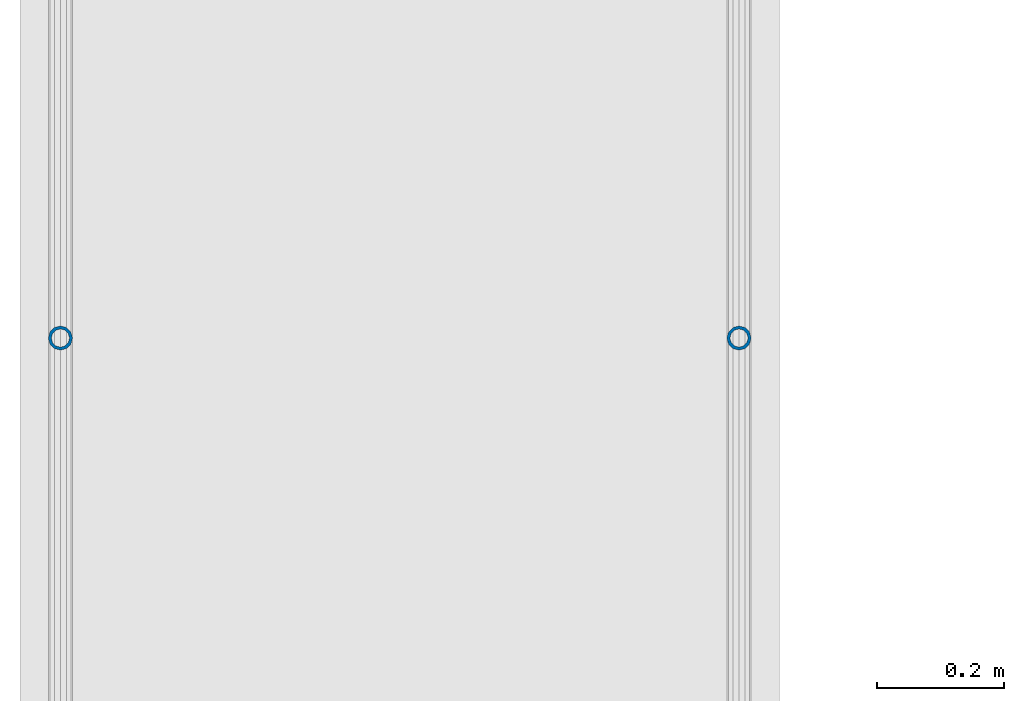
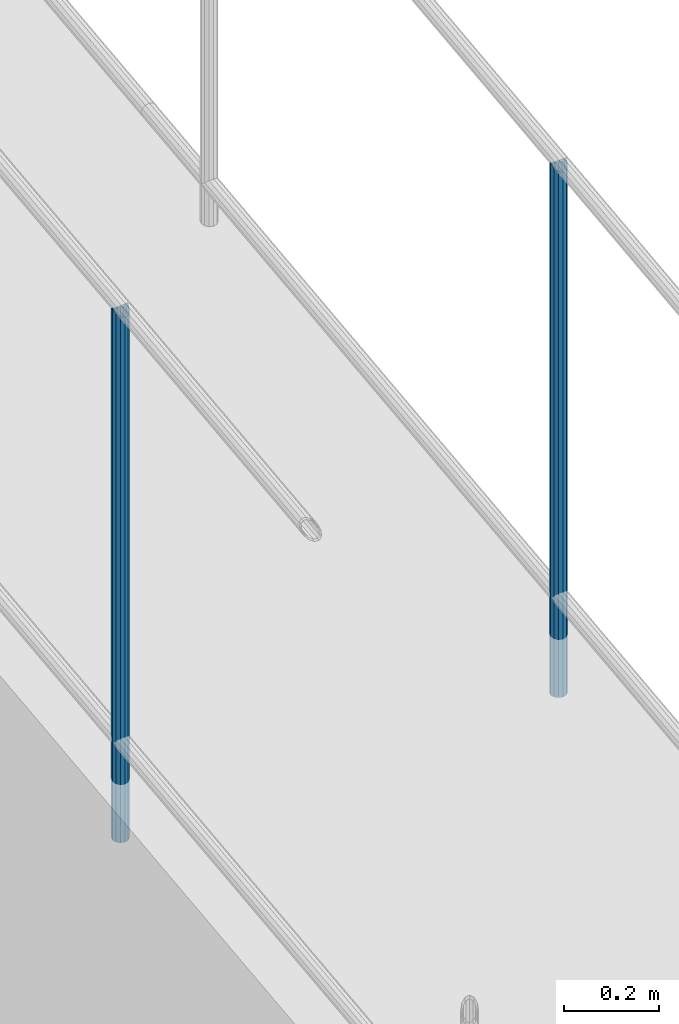
# One storey, part 875 of 1763: 2 columns, 2 elements without a shape of their own.
"""IFC2X3 building model written with IfcOpenShell, lengths in millimetres."""

from ifc_helpers import new_model, si_unit, frame, origin_with_axes, place, context, subcontext, project, spatial, faceted_brep, material, type_object, element, aggregate, save


model = new_model("IFC2X3")

# Units and contexts
model_context = context("Model", 3, precision=1e-05, world=origin_with_axes())
body_context = subcontext(model_context, "Body", "Model", "MODEL_VIEW")
ifc_project = project(units=[si_unit("LENGTHUNIT", "METRE", prefix="MILLI"), si_unit("AREAUNIT", "SQUARE_METRE"), si_unit("VOLUMEUNIT", "CUBIC_METRE"), si_unit("MASSUNIT", "GRAM", prefix="KILO"), si_unit("TIMEUNIT", "SECOND"), si_unit("PLANEANGLEUNIT", "RADIAN"), si_unit("SOLIDANGLEUNIT", "STERADIAN"), si_unit("THERMODYNAMICTEMPERATUREUNIT", "DEGREE_CELSIUS"), si_unit("LUMINOUSINTENSITYUNIT", "LUMEN")], contexts=[model_context])

# Site, building, storey
site_placement = place(None, origin_with_axes())
site = spatial("IfcSite", under=ifc_project, at=site_placement, CompositionType="ELEMENT")
building_placement = place(site_placement, origin_with_axes())
building = spatial("IfcBuilding", under=site, at=building_placement, Name="Undefined", CompositionType="ELEMENT")
storey_placement = place(building_placement, origin_with_axes())
storey = spatial("IfcBuildingStorey", under=building, at=storey_placement, Name="Undefined", CompositionType="ELEMENT", Elevation=0.0)

# Assembly, column
assembly_1_placement = place(storey_placement, origin_with_axes())
assembly_1 = element("IfcElementAssembly", 1, at=assembly_1_placement, inside=storey, Name="GUARDRAIL", AssemblyPlace="NOTDEFINED", PredefinedType="RIGID_FRAME")
ifc_material = material(Name="STEEL/A513")
column_type = type_object("IfcColumnType", PredefinedType="NOTDEFINED")
column_1_placement = place(assembly_1_placement, frame((-97200.6527017878, -3943.5626767489, 4576.43044701569), z_axis=(0.0, -0.999999999989044, 4.68099999989136e-06), x_axis=(0.0, 4.68100000009712e-06, 0.999999999989044)))
column_1 = element("IfcColumn", 2, at=column_1_placement, type_object=column_type, material=ifc_material, Name="POST TUBE", context=body_context, shape_type="Brep", body=[
    faceted_brep([(1371.60074802696, 19.0500000000029, -4.95674612466246e-10), (1360.91954353543, 16.4977839420899, 9.52499999992688), (1363.1068023618, 16.4977839420899, -9.52500000007285), (1352.93166657158, -7.14375000000291, 12.3733379564974), (1350.78515091293, 0.0, 14.2874999999276), (1350.23833620634, 0.0, 19.0499999999279), (1353.10035708436, -9.52499999999418, 16.4977839420208), (1353.84731986472, -9.52499999997963, 9.99208795651202), (1353.84731986473, 9.52500000000873, 9.99208795648292), (1353.10035708436, 9.52499999999418, 16.4977839420208), (1352.93166657157, 7.14375000000291, 12.3733379564974), (1357.04140787087, 12.3733379565674, 7.14374999992697), (1359.7883677507, 14.2875000000058, -7.27595761418343e-11), (1358.68185199063, 12.3733379565674, -7.14375000007294), (1356.14183772056, 9.52500000000873, -9.99208795662844), (1356.88880050093, 9.52499999999418, -16.4977839421663), (1355.77299913398, 7.14375000000291, -12.3733379566434), (1354.06603915248, 0.0, -14.2875000000727), (1354.61285385908, 0.0, -19.0500000000725), (1355.77299913399, -7.14375000000291, -12.3733379566434), (1356.14183772056, -9.52499999997963, -9.992087956658), (1356.88880050093, -9.52499999999418, -16.4977839421663), (1371.60075086449, -19.0499999999884, 1.21417542686686e-10), (1363.1068023618, -16.4977839420899, -9.52500000007285), (1360.91954353543, -16.4977839420899, 9.52499999992688), (1358.68185199066, -12.3733379565674, -7.14375000007294), (1359.78836775073, -14.2875000000058, -7.27595761418343e-11), (1357.0414078709, -12.3733379565674, 7.14374999992697), (0.0, -16.4977839420899, -9.52500000000146), (0.0, -9.52499999999418, -16.4977839420935), (1.45519152283669e-11, 1.81898940354586e-12, -19.0499999999993), (0.0, 9.52499999999418, -16.4977839420935), (0.0, 16.4977839420899, -9.52500000000146), (0.0, 19.0500000000029, 0.0), (0.0, 16.4977839420899, 9.52500000000146), (0.0, 9.52499999999418, 16.4977839420935), (1.45519152283669e-11, 1.81898940354586e-12, 19.0499999999993), (0.0, -9.52499999999418, 16.4977839420935), (0.0, -16.4977839420899, 9.52500000000146), (0.0, -19.0500000000029, 0.0), (0.0, -12.3733379565674, -7.14374999999927), (0.0, -7.14375000000291, -12.373337956571), (0.0, 0.0, -14.2874999999985), (0.0, 7.14375000000291, -12.373337956571), (0.0, 12.3733379565674, -7.14374999999927), (0.0, 14.2875000000058, 0.0), (0.0, 12.3733379565674, 7.14374999999927), (0.0, 7.14375000000291, 12.373337956571), (0.0, 0.0, 14.2874999999985), (0.0, -7.14375000000291, 12.373337956571), (0.0, -12.3733379565674, 7.14374999999927), (0.0, -14.2875000000058, 0.0)], [[[0, 1, 2]], [[3, 4, 5, 6, 7]], [[8, 9, 5, 4, 10]], [[2, 1, 9, 8, 11, 12, 13, 14, 15]], [[15, 14, 16, 17, 18]], [[18, 17, 19, 20, 21]], [[22, 23, 24]], [[21, 20, 25, 26, 27, 7, 6, 24, 23]], [[28, 29, 21, 23]], [[29, 30, 18, 21]], [[30, 31, 15, 18]], [[31, 32, 2, 15]], [[32, 33, 0, 2]], [[33, 34, 1, 0]], [[34, 35, 9, 1]], [[35, 36, 5, 9]], [[36, 37, 6, 5]], [[37, 38, 24, 6]], [[38, 39, 22, 24]], [[39, 28, 23, 22]], [[38, 37, 36, 35, 34, 33, 32, 31, 30, 29, 28, 39], [40, 41, 42, 43, 44, 45, 46, 47, 48, 49, 50, 51]], [[40, 51, 26, 25]], [[19, 41, 40, 25, 20]], [[42, 41, 19, 17]], [[43, 42, 17, 16]], [[44, 43, 16, 14, 13]], [[45, 44, 13, 12]], [[46, 45, 12, 11]], [[10, 47, 46, 11, 8]], [[48, 47, 10, 4]], [[49, 48, 4, 3]], [[50, 49, 3, 7, 27]], [[51, 50, 27, 26]]]),
])
aggregate(assembly_1, [column_1])

assembly_2_placement = place(storey_placement, origin_with_axes())
assembly_2 = element("IfcElementAssembly", 3, at=assembly_2_placement, inside=storey, Name="GUARDRAIL", AssemblyPlace="NOTDEFINED", PredefinedType="RIGID_FRAME")
column_2_placement = place(assembly_2_placement, frame((-96133.8527017878, -3943.5626767489, 4576.43044701569), z_axis=(0.0, -0.999999999989044, 4.68099999989136e-06), x_axis=(0.0, 4.68100000009712e-06, 0.999999999989044)))
column_2 = element("IfcColumn", 4, at=column_2_placement, type_object=column_type, material=ifc_material, Name="POST TUBE", context=body_context, shape_type="Brep", body=[
    faceted_brep([(1371.60074802696, 19.0500000000029, -4.95674612466246e-10), (1360.91954353543, 16.4977839420899, 9.52499999992688), (1363.1068023618, 16.4977839420899, -9.52500000007285), (1352.93166657158, -7.14375000000291, 12.3733379564974), (1350.78515091293, 0.0, 14.2874999999276), (1350.23833620634, 0.0, 19.0499999999279), (1353.10035708436, -9.52499999999418, 16.4977839420208), (1353.84731986472, -9.52499999997963, 9.99208795651202), (1353.84731986473, 9.52500000000873, 9.99208795648292), (1353.10035708436, 9.52499999999418, 16.4977839420208), (1352.93166657157, 7.14375000000291, 12.3733379564974), (1357.04140787087, 12.3733379565674, 7.14374999992697), (1359.7883677507, 14.2875000000058, -7.27595761418343e-11), (1358.68185199063, 12.3733379565674, -7.14375000007294), (1356.14183772056, 9.52500000000873, -9.99208795662844), (1356.88880050093, 9.52499999999418, -16.4977839421663), (1355.77299913398, 7.14375000000291, -12.3733379566434), (1354.06603915248, 0.0, -14.2875000000727), (1354.61285385908, 0.0, -19.0500000000725), (1355.77299913399, -7.14375000000291, -12.3733379566434), (1356.14183772056, -9.52499999997963, -9.992087956658), (1356.88880050093, -9.52499999999418, -16.4977839421663), (1371.60075086449, -19.0499999999884, 1.21417542686686e-10), (1363.1068023618, -16.4977839420899, -9.52500000007285), (1360.91954353543, -16.4977839420899, 9.52499999992688), (1358.68185199066, -12.3733379565674, -7.14375000007294), (1359.78836775073, -14.2875000000058, -7.27595761418343e-11), (1357.0414078709, -12.3733379565674, 7.14374999992697), (0.0, -16.4977839420899, -9.52500000000146), (0.0, -9.52499999999418, -16.4977839420935), (1.45519152283669e-11, 1.81898940354586e-12, -19.0499999999993), (0.0, 9.52499999999418, -16.4977839420935), (0.0, 16.4977839420899, -9.52500000000146), (0.0, 19.0500000000029, 0.0), (0.0, 16.4977839420899, 9.52500000000146), (0.0, 9.52499999999418, 16.4977839420935), (1.45519152283669e-11, 1.81898940354586e-12, 19.0499999999993), (0.0, -9.52499999999418, 16.4977839420935), (0.0, -16.4977839420899, 9.52500000000146), (0.0, -19.0500000000029, 0.0), (0.0, -12.3733379565674, -7.14374999999927), (0.0, -7.14375000000291, -12.373337956571), (0.0, 0.0, -14.2874999999985), (0.0, 7.14375000000291, -12.373337956571), (0.0, 12.3733379565674, -7.14374999999927), (0.0, 14.2875000000058, 0.0), (0.0, 12.3733379565674, 7.14374999999927), (0.0, 7.14375000000291, 12.373337956571), (0.0, 0.0, 14.2874999999985), (0.0, -7.14375000000291, 12.373337956571), (0.0, -12.3733379565674, 7.14374999999927), (0.0, -14.2875000000058, 0.0)], [[[0, 1, 2]], [[3, 4, 5, 6, 7]], [[8, 9, 5, 4, 10]], [[2, 1, 9, 8, 11, 12, 13, 14, 15]], [[15, 14, 16, 17, 18]], [[18, 17, 19, 20, 21]], [[22, 23, 24]], [[21, 20, 25, 26, 27, 7, 6, 24, 23]], [[28, 29, 21, 23]], [[29, 30, 18, 21]], [[30, 31, 15, 18]], [[31, 32, 2, 15]], [[32, 33, 0, 2]], [[33, 34, 1, 0]], [[34, 35, 9, 1]], [[35, 36, 5, 9]], [[36, 37, 6, 5]], [[37, 38, 24, 6]], [[38, 39, 22, 24]], [[39, 28, 23, 22]], [[38, 37, 36, 35, 34, 33, 32, 31, 30, 29, 28, 39], [40, 41, 42, 43, 44, 45, 46, 47, 48, 49, 50, 51]], [[40, 51, 26, 25]], [[19, 41, 40, 25, 20]], [[42, 41, 19, 17]], [[43, 42, 17, 16]], [[44, 43, 16, 14, 13]], [[45, 44, 13, 12]], [[46, 45, 12, 11]], [[10, 47, 46, 11, 8]], [[48, 47, 10, 4]], [[49, 48, 4, 3]], [[50, 49, 3, 7, 27]], [[51, 50, 27, 26]]]),
])
aggregate(assembly_2, [column_2])

save(model, "model.ifc")
